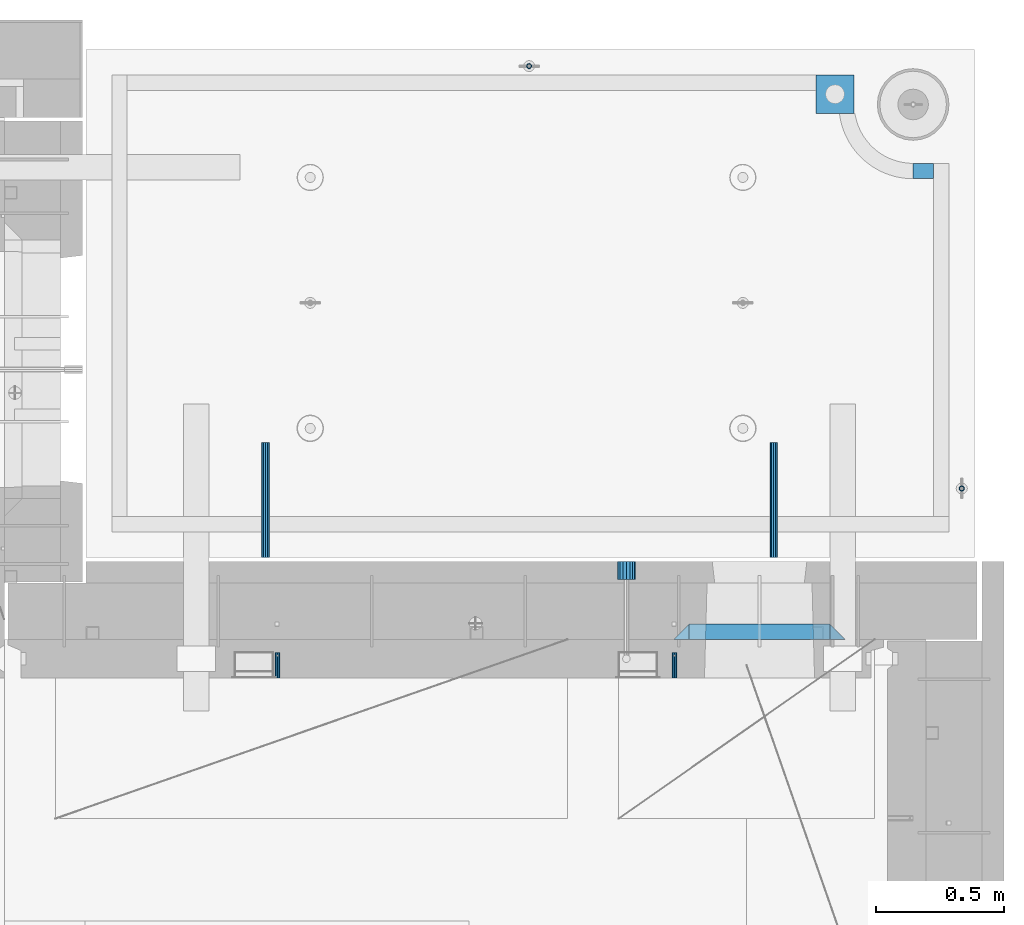
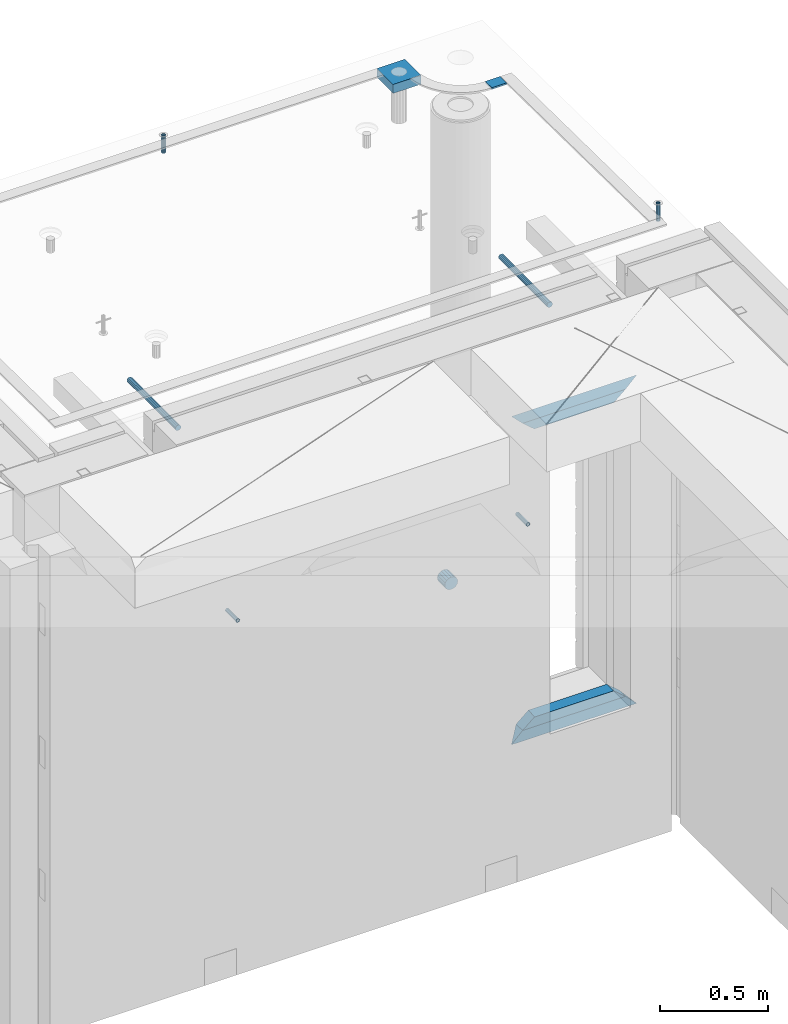
# One storey, part 165 of 341: 13 beams, 8 elements without a shape of their own.
"""IFC2X3 building model written with IfcOpenShell, lengths in millimetres."""

from ifc_helpers import new_model, si_unit, frame, origin_with_axes, place, context, subcontext, project, spatial, faceted_brep, material, type_object, element, aggregate, save


model = new_model("IFC2X3")

# Units and contexts
model_context = context("Model", 3, precision=1e-05, world=origin_with_axes())
body_context = subcontext(model_context, "Body", "Model", "MODEL_VIEW")
ifc_project = project(units=[si_unit("LENGTHUNIT", "METRE", prefix="MILLI"), si_unit("AREAUNIT", "SQUARE_METRE"), si_unit("VOLUMEUNIT", "CUBIC_METRE"), si_unit("MASSUNIT", "GRAM", prefix="KILO"), si_unit("TIMEUNIT", "SECOND"), si_unit("PLANEANGLEUNIT", "RADIAN"), si_unit("SOLIDANGLEUNIT", "STERADIAN"), si_unit("THERMODYNAMICTEMPERATUREUNIT", "DEGREE_CELSIUS"), si_unit("LUMINOUSINTENSITYUNIT", "LUMEN")], contexts=[model_context])

# Site, building, storey
site_placement = place(None, origin_with_axes())
site = spatial("IfcSite", under=ifc_project, at=site_placement, CompositionType="ELEMENT")
building_placement = place(site_placement, origin_with_axes())
building = spatial("IfcBuilding", under=site, at=building_placement, CompositionType="ELEMENT")
storey_placement = place(building_placement, origin_with_axes())
storey = spatial("IfcBuildingStorey", under=building, at=storey_placement, Name="5", CompositionType="ELEMENT", Elevation=0.0)

# Assembly, beam
assembly_1_placement = place(storey_placement, origin_with_axes())
assembly_1 = element("IfcElementAssembly", 1, at=assembly_1_placement, inside=storey, AssemblyPlace="NOTDEFINED", PredefinedType="REINFORCEMENT_UNIT")
ifc_material_1 = material(Name="CONCRETE/Concrete_Undefined")
beam_type_1 = type_object("IfcBeamType", PredefinedType="NOTDEFINED")
beam_1_placement = place(assembly_1_placement, frame((34629.9388785763, 22710.0581582943, 96683.7829850799), z_axis=(-0.00137996799978526, 4.79999998713041e-07, 0.999999047843591), x_axis=(0.999998987436327, -0.000347584000148161, 0.00137996800063524)))
beam_1 = element("IfcBeam", 2, at=beam_1_placement, type_object=beam_type_1, material=ifc_material_1, context=body_context, shape_type="Brep", body=[
    faceted_brep([(0.0, 75.0, -25.0), (1.81898940354586e-12, 75.0, 25.0), (149.995899162379, 75.0, 25.0), (149.995899158246, 75.0000000000036, -25.0), (1.81898940354586e-12, -75.0000000000009, 25.0), (149.995899162386, -75.0, 25.0), (0.0, -75.0, -25.0), (149.995899158239, -74.9999999999964, -25.0)], [[[0, 1, 2, 3]], [[1, 4, 5, 2]], [[4, 6, 7, 5]], [[6, 0, 3, 7]], [[5, 7, 3, 2]], [[6, 4, 1, 0]]]),
])

# Assemblies, beams
assembly_2_placement = place(storey_placement, origin_with_axes())
assembly_2 = element("IfcElementAssembly", 3, at=assembly_2_placement, inside=storey, AssemblyPlace="NOTDEFINED", PredefinedType="REINFORCEMENT_UNIT")
assembly_3_placement = place(assembly_2_placement, origin_with_axes())
assembly_3 = element("IfcElementAssembly", 4, at=assembly_3_placement, Name="Steel Assembly", AssemblyPlace="NOTDEFINED", PredefinedType="RIGID_FRAME")
ifc_material_2 = material(Name="STEEL/Steel_Undefined")
beam_type_2 = type_object("IfcBeamType", PredefinedType="NOTDEFINED")
beam_2_placement = place(assembly_3_placement, frame((34077.8782931989, 20429.9951872276, 95755.0), z_axis=(-1.0, 3.00000001838171e-08, 0.0), x_axis=(0.0, 1.0, 0.0)))
beam_2 = element("IfcBeam", 5, at=beam_2_placement, type_object=beam_type_2, material=ifc_material_2, Name="M16", context=body_context, shape_type="Brep", body=[
    faceted_brep([(0.0, -8.49999999999272, -1.45519152283669e-11), (0.0, -7.36121593215648, 4.24999999998545), (100.000000000262, -7.36121593215648, 4.24999999998545), (100.000000000262, -8.49999999999272, -1.45519152283669e-11), (0.0, -4.24999999998545, 7.36121593216376), (100.000000000262, -4.24999999998545, 7.36121593216376), (0.0, 1.45519152283669e-11, 8.49999999998545), (100.000000000262, 1.45519152283669e-11, 8.49999999998545), (0.0, 4.25000000001455, 7.36121593216376), (100.000000000262, 4.25000000001455, 7.36121593216376), (0.0, 7.36121593217104, 4.24999999998545), (100.000000000262, 7.36121593217104, 4.24999999998545), (0.0, 8.50000000000728, 0.0), (100.000000000262, 8.50000000000728, 0.0), (0.0, 7.36121593217104, -4.25000000001455), (100.000000000262, 7.36121593217104, -4.25000000001455), (0.0, 4.25000000000728, -7.36121593219286), (100.000000000262, 4.25000000000728, -7.36121593219286), (0.0, 7.27595761418343e-12, -8.5), (100.000000000262, 7.27595761418343e-12, -8.5), (0.0, -4.24999999999272, -7.36121593217831), (100.000000000262, -4.24999999999272, -7.36121593217831), (0.0, -7.36121593215648, -4.25), (100.000000000262, -7.36121593215648, -4.25), (0.0, -10.4999999999927, -1.45519152283669e-11), (0.0, -9.09326673972828, -5.25000000001455), (100.000000000262, -9.09326673972828, -5.25000000001455), (100.000000000262, -10.4999999999927, -1.45519152283669e-11), (0.0, -5.24999999998545, -9.09326673974283), (100.000000000262, -5.24999999998545, -9.09326673974283), (0.0, 7.27595761418343e-12, -10.5), (100.000000000262, 7.27595761418343e-12, -10.5), (0.0, 5.25000000001455, -9.09326673975738), (100.000000000262, 5.25000000001455, -9.09326673975738), (0.0, 9.09326673975011, -5.25000000001455), (100.000000000262, 9.09326673975011, -5.25000000001455), (0.0, 10.5000000000073, -1.45519152283669e-11), (100.000000000262, 10.5000000000073, -1.45519152283669e-11), (0.0, 9.09326673975011, 5.25), (100.000000000262, 9.09326673975011, 5.25), (0.0, 5.25000000000728, 9.09326673972828), (100.000000000262, 5.25000000000728, 9.09326673972828), (0.0, 1.45519152283669e-11, 10.4999999999854), (100.000000000262, 1.45519152283669e-11, 10.4999999999854), (0.0, -5.24999999999272, 9.09326673972828), (100.000000000262, -5.24999999999272, 9.09326673972828), (0.0, -9.09326673972828, 5.24999999998545), (100.000000000262, -9.09326673972828, 5.24999999998545)], [[[0, 1, 2, 3]], [[1, 4, 5, 2]], [[4, 6, 7, 5]], [[6, 8, 9, 7]], [[8, 10, 11, 9]], [[10, 12, 13, 11]], [[12, 14, 15, 13]], [[14, 16, 17, 15]], [[16, 18, 19, 17]], [[18, 20, 21, 19]], [[20, 22, 23, 21]], [[22, 0, 3, 23]], [[24, 25, 26, 27]], [[25, 28, 29, 26]], [[28, 30, 31, 29]], [[30, 32, 33, 31]], [[32, 34, 35, 33]], [[34, 36, 37, 35]], [[36, 38, 39, 37]], [[38, 40, 41, 39]], [[40, 42, 43, 41]], [[42, 44, 45, 43]], [[44, 46, 47, 45]], [[46, 24, 27, 47]], [[29, 31, 33, 35, 37, 39, 41, 43, 45, 47, 27, 26], [5, 7, 9, 11, 13, 15, 17, 19, 21, 23, 3, 2]], [[46, 44, 42, 40, 38, 36, 34, 32, 30, 28, 25, 24], [22, 20, 18, 16, 14, 12, 10, 8, 6, 4, 1, 0]]]),
])
aggregate(assembly_3, [beam_2])
assembly_4_placement = place(assembly_2_placement, origin_with_axes())
assembly_4 = element("IfcElementAssembly", 6, at=assembly_4_placement, Name="Steel Assembly", AssemblyPlace="NOTDEFINED", PredefinedType="RIGID_FRAME")
beam_3_placement = place(assembly_4_placement, frame((32527.3782931989, 20429.9951872276, 95755.0), z_axis=(-1.0, 3.00000001838171e-08, 0.0), x_axis=(0.0, 1.0, 0.0)))
beam_3 = element("IfcBeam", 7, at=beam_3_placement, type_object=beam_type_2, material=ifc_material_2, Name="M16", context=body_context, shape_type="Brep", body=[
    faceted_brep([(0.0, -8.49999999999272, -1.45519152283669e-11), (0.0, -7.36121593215648, 4.24999999998545), (100.000000000262, -7.36121593215648, 4.24999999998545), (100.000000000262, -8.49999999999272, -1.45519152283669e-11), (0.0, -4.24999999998545, 7.36121593216376), (100.000000000262, -4.24999999998545, 7.36121593216376), (0.0, 1.45519152283669e-11, 8.49999999998545), (100.000000000262, 1.45519152283669e-11, 8.49999999998545), (0.0, 4.25000000001455, 7.36121593216376), (100.000000000262, 4.25000000001455, 7.36121593216376), (0.0, 7.36121593217104, 4.24999999998545), (100.000000000262, 7.36121593217104, 4.24999999998545), (0.0, 8.50000000000728, 0.0), (100.000000000262, 8.50000000000728, 0.0), (0.0, 7.36121593217104, -4.25000000001455), (100.000000000262, 7.36121593217104, -4.25000000001455), (0.0, 4.25000000000728, -7.36121593219286), (100.000000000262, 4.25000000000728, -7.36121593219286), (0.0, 7.27595761418343e-12, -8.5), (100.000000000262, 7.27595761418343e-12, -8.5), (0.0, -4.24999999999272, -7.36121593217831), (100.000000000262, -4.24999999999272, -7.36121593217831), (0.0, -7.36121593215648, -4.25), (100.000000000262, -7.36121593215648, -4.25), (0.0, -10.4999999999927, -1.45519152283669e-11), (0.0, -9.09326673972828, -5.25000000001455), (100.000000000262, -9.09326673972828, -5.25000000001455), (100.000000000262, -10.4999999999927, -1.45519152283669e-11), (0.0, -5.24999999998545, -9.09326673974283), (100.000000000262, -5.24999999998545, -9.09326673974283), (0.0, 7.27595761418343e-12, -10.5), (100.000000000262, 7.27595761418343e-12, -10.5), (0.0, 5.25000000001455, -9.09326673975738), (100.000000000262, 5.25000000001455, -9.09326673975738), (0.0, 9.09326673975011, -5.25000000001455), (100.000000000262, 9.09326673975011, -5.25000000001455), (0.0, 10.5000000000073, -1.45519152283669e-11), (100.000000000262, 10.5000000000073, -1.45519152283669e-11), (0.0, 9.09326673975011, 5.25), (100.000000000262, 9.09326673975011, 5.25), (0.0, 5.25000000000728, 9.09326673972828), (100.000000000262, 5.25000000000728, 9.09326673972828), (0.0, 1.45519152283669e-11, 10.4999999999854), (100.000000000262, 1.45519152283669e-11, 10.4999999999854), (0.0, -5.24999999999272, 9.09326673972828), (100.000000000262, -5.24999999999272, 9.09326673972828), (0.0, -9.09326673972828, 5.24999999998545), (100.000000000262, -9.09326673972828, 5.24999999998545)], [[[0, 1, 2, 3]], [[1, 4, 5, 2]], [[4, 6, 7, 5]], [[6, 8, 9, 7]], [[8, 10, 11, 9]], [[10, 12, 13, 11]], [[12, 14, 15, 13]], [[14, 16, 17, 15]], [[16, 18, 19, 17]], [[18, 20, 21, 19]], [[20, 22, 23, 21]], [[22, 0, 3, 23]], [[24, 25, 26, 27]], [[25, 28, 29, 26]], [[28, 30, 31, 29]], [[30, 32, 33, 31]], [[32, 34, 35, 33]], [[34, 36, 37, 35]], [[36, 38, 39, 37]], [[38, 40, 41, 39]], [[40, 42, 43, 41]], [[42, 44, 45, 43]], [[44, 46, 47, 45]], [[46, 24, 27, 47]], [[29, 31, 33, 35, 37, 39, 41, 43, 45, 47, 27, 26], [5, 7, 9, 11, 13, 15, 17, 19, 21, 23, 3, 2]], [[46, 44, 42, 40, 38, 36, 34, 32, 30, 28, 25, 24], [22, 20, 18, 16, 14, 12, 10, 8, 6, 4, 1, 0]]]),
])
aggregate(assembly_4, [beam_3])

# Assembly, beam
assembly_5_placement = place(assembly_1_placement, origin_with_axes())
assembly_5 = element("IfcElementAssembly", 8, at=assembly_5_placement, Name="Steel Assembly", AssemblyPlace="NOTDEFINED", PredefinedType="RIGID_FRAME")
ifc_material_3 = material(Name="STEEL/1.4301")
beam_type_3 = type_object("IfcBeamType", PredefinedType="NOTDEFINED")
beam_4_placement = place(assembly_5_placement, frame((35199.9998195516, 21170.0002421324, 96731.000000009), z_axis=(0.999999999984675, 3.40399999908427e-06, -4.36599999368485e-06), x_axis=(-4.36599999292741e-06, 0.0, -0.999999999990469)))
beam_4 = element("IfcBeam", 9, at=beam_4_placement, type_object=beam_type_3, material=ifc_material_3, context=body_context, shape_type="Brep", body=[
    faceted_brep([(0.0, -8.0, 0.0), (0.0, -6.92820323027263, 4.0), (100.000000000029, -6.92820323027263, 4.0), (100.000000000029, -7.99999999999636, 0.0), (0.0, -4.0, 6.92820323027627), (100.000000000029, -4.0, 6.92820323027536), (0.0, 0.0, 8.0), (100.000000000029, 3.63797880709171e-12, 8.0), (0.0, 4.0, 6.92820323027627), (100.000000000029, 4.0, 6.92820323027536), (0.0, 6.92820323027263, 4.0), (100.000000000029, 6.92820323027627, 3.99999999999909), (0.0, 8.0, 0.0), (100.000000000029, 8.0, 0.0), (0.0, 6.92820323027263, -4.0), (100.000000000029, 6.92820323027627, -4.00000000000091), (0.0, 4.0, -6.92820323027627), (100.000000000029, 4.00000000000364, -6.92820323027536), (0.0, 0.0, -8.0), (100.000000000029, 3.63797880709171e-12, -8.00000000000091), (0.0, -4.0, -6.92820323027627), (100.000000000029, -3.99999999999636, -6.92820323027627), (0.0, -6.92820323027263, -4.0), (100.000000000029, -6.92820323027263, -4.0), (0.0, -10.4999999999927, -1.45519152283669e-11), (0.0, -9.09326673972828, -5.25000000001455), (100.000000000262, -9.09326673972828, -5.25000000001455), (100.000000000262, -10.4999999999927, -1.45519152283669e-11), (0.0, -5.24999999998545, -9.09326673974283), (100.000000000262, -5.24999999998545, -9.09326673974283), (0.0, 7.27595761418343e-12, -10.5), (100.000000000262, 7.27595761418343e-12, -10.5), (0.0, 5.25000000001455, -9.09326673975738), (100.000000000262, 5.25000000001455, -9.09326673975738), (0.0, 9.09326673975011, -5.25000000001455), (100.000000000262, 9.09326673975011, -5.25000000001455), (0.0, 10.5000000000073, -1.45519152283669e-11), (100.000000000262, 10.5000000000073, -1.45519152283669e-11), (0.0, 9.09326673975011, 5.25), (100.000000000262, 9.09326673975011, 5.25), (0.0, 5.25000000000728, 9.09326673972828), (100.000000000262, 5.25000000000728, 9.09326673972828), (0.0, 1.45519152283669e-11, 10.4999999999854), (100.000000000262, 1.45519152283669e-11, 10.4999999999854), (0.0, -5.24999999999272, 9.09326673972828), (100.000000000262, -5.24999999999272, 9.09326673972828), (0.0, -9.09326673972828, 5.24999999998545), (100.000000000262, -9.09326673972828, 5.24999999998545)], [[[0, 1, 2, 3]], [[1, 4, 5, 2]], [[4, 6, 7, 5]], [[6, 8, 9, 7]], [[8, 10, 11, 9]], [[10, 12, 13, 11]], [[12, 14, 15, 13]], [[14, 16, 17, 15]], [[16, 18, 19, 17]], [[18, 20, 21, 19]], [[20, 22, 23, 21]], [[22, 0, 3, 23]], [[24, 25, 26, 27]], [[25, 28, 29, 26]], [[28, 30, 31, 29]], [[30, 32, 33, 31]], [[32, 34, 35, 33]], [[34, 36, 37, 35]], [[36, 38, 39, 37]], [[38, 40, 41, 39]], [[40, 42, 43, 41]], [[42, 44, 45, 43]], [[44, 46, 47, 45]], [[46, 24, 27, 47]], [[29, 31, 33, 35, 37, 39, 41, 43, 45, 47, 27, 26], [5, 7, 9, 11, 13, 15, 17, 19, 21, 23, 3, 2]], [[46, 44, 42, 40, 38, 36, 34, 32, 30, 28, 25, 24], [22, 20, 18, 16, 14, 12, 10, 8, 6, 4, 1, 0]]]),
])
aggregate(assembly_5, [beam_4])

assembly_6_placement = place(assembly_1_placement, origin_with_axes())
assembly_6 = element("IfcElementAssembly", 10, at=assembly_6_placement, Name="Steel Assembly", AssemblyPlace="NOTDEFINED", PredefinedType="RIGID_FRAME")
beam_5_placement = place(assembly_6_placement, frame((33509.996713687, 22819.9969702071, 96706.0000000179), z_axis=(3.62999999922404e-06, -0.999999999993412, 0.0), x_axis=(-4.36599999292741e-06, 0.0, -0.999999999990469)))
beam_5 = element("IfcBeam", 11, at=beam_5_placement, type_object=beam_type_3, material=ifc_material_3, context=body_context, shape_type="Brep", body=[
    faceted_brep([(0.0, -8.0, 0.0), (0.0, -6.92820323027263, 4.0), (100.000000000029, -6.92820323027263, 4.0), (100.000000000029, -7.99999999999636, 0.0), (0.0, -4.0, 6.92820323027627), (100.000000000029, -4.0, 6.92820323027536), (0.0, 0.0, 8.0), (100.000000000029, 3.63797880709171e-12, 8.0), (0.0, 4.0, 6.92820323027627), (100.000000000029, 4.0, 6.92820323027536), (0.0, 6.92820323027263, 4.0), (100.000000000029, 6.92820323027627, 3.99999999999909), (0.0, 8.0, 0.0), (100.000000000029, 8.0, 0.0), (0.0, 6.92820323027263, -4.0), (100.000000000029, 6.92820323027627, -4.00000000000091), (0.0, 4.0, -6.92820323027627), (100.000000000029, 4.00000000000364, -6.92820323027536), (0.0, 0.0, -8.0), (100.000000000029, 3.63797880709171e-12, -8.00000000000091), (0.0, -4.0, -6.92820323027627), (100.000000000029, -3.99999999999636, -6.92820323027627), (0.0, -6.92820323027263, -4.0), (100.000000000029, -6.92820323027263, -4.0), (0.0, -10.4999999999927, -1.45519152283669e-11), (0.0, -9.09326673972828, -5.25000000001455), (100.000000000262, -9.09326673972828, -5.25000000001455), (100.000000000262, -10.4999999999927, -1.45519152283669e-11), (0.0, -5.24999999998545, -9.09326673974283), (100.000000000262, -5.24999999998545, -9.09326673974283), (0.0, 7.27595761418343e-12, -10.5), (100.000000000262, 7.27595761418343e-12, -10.5), (0.0, 5.25000000001455, -9.09326673975738), (100.000000000262, 5.25000000001455, -9.09326673975738), (0.0, 9.09326673975011, -5.25000000001455), (100.000000000262, 9.09326673975011, -5.25000000001455), (0.0, 10.5000000000073, -1.45519152283669e-11), (100.000000000262, 10.5000000000073, -1.45519152283669e-11), (0.0, 9.09326673975011, 5.25), (100.000000000262, 9.09326673975011, 5.25), (0.0, 5.25000000000728, 9.09326673972828), (100.000000000262, 5.25000000000728, 9.09326673972828), (0.0, 1.45519152283669e-11, 10.4999999999854), (100.000000000262, 1.45519152283669e-11, 10.4999999999854), (0.0, -5.24999999999272, 9.09326673972828), (100.000000000262, -5.24999999999272, 9.09326673972828), (0.0, -9.09326673972828, 5.24999999998545), (100.000000000262, -9.09326673972828, 5.24999999998545)], [[[0, 1, 2, 3]], [[1, 4, 5, 2]], [[4, 6, 7, 5]], [[6, 8, 9, 7]], [[8, 10, 11, 9]], [[10, 12, 13, 11]], [[12, 14, 15, 13]], [[14, 16, 17, 15]], [[16, 18, 19, 17]], [[18, 20, 21, 19]], [[20, 22, 23, 21]], [[22, 0, 3, 23]], [[24, 25, 26, 27]], [[25, 28, 29, 26]], [[28, 30, 31, 29]], [[30, 32, 33, 31]], [[32, 34, 35, 33]], [[34, 36, 37, 35]], [[36, 38, 39, 37]], [[38, 40, 41, 39]], [[40, 42, 43, 41]], [[42, 44, 45, 43]], [[44, 46, 47, 45]], [[46, 24, 27, 47]], [[29, 31, 33, 35, 37, 39, 41, 43, 45, 47, 27, 26], [5, 7, 9, 11, 13, 15, 17, 19, 21, 23, 3, 2]], [[46, 44, 42, 40, 38, 36, 34, 32, 30, 28, 25, 24], [22, 20, 18, 16, 14, 12, 10, 8, 6, 4, 1, 0]]]),
])
aggregate(assembly_6, [beam_5])

# Beam
ifc_material_4 = material()
beam_type_4 = type_object("IfcBeamType", Name="D70", PredefinedType="NOTDEFINED")
beam_6_placement = place(assembly_2_placement, frame((33889.9951872276, 20884.9951872276, 95255.0), z_axis=(0.0, 0.0, 1.0), x_axis=(0.0, -1.0, 0.0)))
beam_6 = element("IfcBeam", 12, at=beam_6_placement, type_object=beam_type_4, material=ifc_material_4, ObjectType="D70", context=body_context, shape_type="Brep", body=[
    faceted_brep([(0.0, -35.0, 0.0), (0.0, -32.3357836378964, -13.3939201327739), (70.0, -32.3357836378964, -13.3939201327739), (70.0, -35.0, 0.0), (0.0, -24.7487373415279, -24.7487373415352), (70.0, -24.7487373415279, -24.7487373415352), (0.0, -13.3939201327776, -32.3357836379), (70.0, -13.3939201327776, -32.3357836379), (0.0, 0.0, -35.0), (70.0, 0.0, -35.0), (0.0, 13.3939201327776, -32.3357836379), (70.0, 13.3939201327776, -32.3357836379), (0.0, 24.7487373415279, -24.7487373415352), (70.0, 24.7487373415279, -24.7487373415352), (0.0, 32.3357836378964, -13.3939201327739), (70.0, 32.3357836378964, -13.3939201327739), (0.0, 35.0, 0.0), (70.0, 35.0, 0.0), (0.0, 32.3357836378964, 13.3939201327739), (70.0, 32.3357836378964, 13.3939201327739), (0.0, 24.7487373415279, 24.7487373415352), (70.0, 24.7487373415279, 24.7487373415352), (0.0, 13.3939201327776, 32.3357836379), (70.0, 13.3939201327776, 32.3357836379), (0.0, 0.0, 35.0), (70.0, 0.0, 35.0), (0.0, -13.3939201327776, 32.3357836379), (70.0, -13.3939201327776, 32.3357836379), (0.0, -24.7487373415279, 24.7487373415352), (70.0, -24.7487373415279, 24.7487373415352), (0.0, -32.3357836378964, 13.3939201327739), (70.0, -32.3357836378964, 13.3939201327739)], [[[0, 1, 2, 3]], [[1, 4, 5, 2]], [[4, 6, 7, 5]], [[6, 8, 9, 7]], [[8, 10, 11, 9]], [[10, 12, 13, 11]], [[12, 14, 15, 13]], [[14, 16, 17, 15]], [[16, 18, 19, 17]], [[18, 20, 21, 19]], [[20, 22, 23, 21]], [[22, 24, 25, 23]], [[24, 26, 27, 25]], [[26, 28, 29, 27]], [[28, 30, 31, 29]], [[30, 0, 3, 31]], [[5, 7, 9, 11, 13, 15, 17, 19, 21, 23, 25, 27, 29, 31, 3, 2]], [[30, 28, 26, 24, 22, 20, 18, 16, 14, 12, 10, 8, 6, 4, 1, 0]]]),
])

# Assembly, beam
assembly_7_placement = place(assembly_1_placement, origin_with_axes())
assembly_7 = element("IfcElementAssembly", 13, at=assembly_7_placement, Name="Steel Assembly", AssemblyPlace="NOTDEFINED", PredefinedType="RIGID_FRAME")
ifc_material_5 = material(Name="STEEL/S235JR")
beam_type_5 = type_object("IfcBeamType", Name="D30", PredefinedType="NOTDEFINED")
beam_7_placement = place(assembly_7_placement, frame((32479.9998567563, 20900.0253394533, 96575.0), z_axis=(0.0, 0.0, 1.0), x_axis=(0.0, 1.0, 0.0)))
beam_7 = element("IfcBeam", 14, at=beam_7_placement, type_object=beam_type_5, material=ifc_material_5, Name="Rd30", ObjectType="D30", context=body_context, shape_type="Brep", body=[
    faceted_brep([(0.0, -15.0, 0.0), (0.0, -12.9903810567666, -7.5), (450.0, -12.9903810567666, -7.5), (450.0, -15.0, 0.0), (0.0, -7.5, -12.9903810567666), (450.0, -7.5, -12.990381056763), (0.0, 0.0, -15.0), (450.0, 0.0, -15.0), (0.0, 7.5, -12.9903810567666), (450.0, 7.5, -12.990381056763), (0.0, 12.9903810567666, -7.5), (450.0, 12.9903810567666, -7.5), (0.0, 15.0, 0.0), (450.0, 15.0, 0.0), (0.0, 12.9903810567666, 7.5), (450.0, 12.9903810567666, 7.5), (0.0, 7.5, 12.9903810567666), (450.0, 7.5, 12.990381056763), (0.0, 0.0, 15.0), (450.0, 0.0, 15.0), (0.0, -7.5, 12.9903810567666), (450.0, -7.5, 12.990381056763), (0.0, -12.9903810567666, 7.5), (450.0, -12.9903810567666, 7.5)], [[[0, 1, 2, 3]], [[1, 4, 5, 2]], [[4, 6, 7, 5]], [[6, 8, 9, 7]], [[8, 10, 11, 9]], [[10, 12, 13, 11]], [[12, 14, 15, 13]], [[14, 16, 17, 15]], [[16, 18, 19, 17]], [[18, 20, 21, 19]], [[20, 22, 23, 21]], [[22, 0, 3, 23]], [[5, 7, 9, 11, 13, 15, 17, 19, 21, 23, 3, 2]], [[22, 20, 18, 16, 14, 12, 10, 8, 6, 4, 1, 0]]]),
])
aggregate(assembly_7, [beam_7])

assembly_8_placement = place(assembly_1_placement, origin_with_axes())
assembly_8 = element("IfcElementAssembly", 15, at=assembly_8_placement, Name="Steel Assembly", AssemblyPlace="NOTDEFINED", PredefinedType="RIGID_FRAME")
beam_8_placement = place(assembly_8_placement, frame((34464.9998570066, 20900.0152136098, 96575.0), z_axis=(0.0, 0.0, 1.0), x_axis=(0.0, 1.0, 0.0)))
beam_8 = element("IfcBeam", 16, at=beam_8_placement, type_object=beam_type_5, material=ifc_material_5, Name="Rd30", ObjectType="D30", context=body_context, shape_type="Brep", body=[
    faceted_brep([(0.0, -15.0, 0.0), (0.0, -12.9903810567666, -7.5), (450.0, -12.9903810567666, -7.5), (450.0, -15.0, 0.0), (0.0, -7.5, -12.9903810567666), (450.0, -7.5, -12.990381056763), (0.0, 0.0, -15.0), (450.0, 0.0, -15.0), (0.0, 7.5, -12.9903810567666), (450.0, 7.5, -12.990381056763), (0.0, 12.9903810567666, -7.5), (450.0, 12.9903810567666, -7.5), (0.0, 15.0, 0.0), (450.0, 15.0, 0.0), (0.0, 12.9903810567666, 7.5), (450.0, 12.9903810567666, 7.5), (0.0, 7.5, 12.9903810567666), (450.0, 7.5, 12.990381056763), (0.0, 0.0, 15.0), (450.0, 0.0, 15.0), (0.0, -7.5, 12.9903810567666), (450.0, -7.5, 12.990381056763), (0.0, -12.9903810567666, 7.5), (450.0, -12.9903810567666, 7.5)], [[[0, 1, 2, 3]], [[1, 4, 5, 2]], [[4, 6, 7, 5]], [[6, 8, 9, 7]], [[8, 10, 11, 9]], [[10, 12, 13, 11]], [[12, 14, 15, 13]], [[14, 16, 17, 15]], [[16, 18, 19, 17]], [[18, 20, 21, 19]], [[20, 22, 23, 21]], [[22, 0, 3, 23]], [[5, 7, 9, 11, 13, 15, 17, 19, 21, 23, 3, 2]], [[22, 20, 18, 16, 14, 12, 10, 8, 6, 4, 1, 0]]]),
])
aggregate(assembly_8, [beam_8])

# Beam
beam_type_6 = type_object("IfcBeamType", PredefinedType="NOTDEFINED")
beam_9_placement = place(assembly_1_placement, frame((35010.002279683, 22410.0178789446, 96707.3588950719), z_axis=(-0.00268578700072087, 6.80000012107549e-08, 0.999996393267587), x_axis=(0.999996392945569, -2.53780000005236e-05, 0.00268578699982978)))
beam_9 = element("IfcBeam", 17, at=beam_9_placement, type_object=beam_type_6, material=ifc_material_1, context=body_context, shape_type="Brep", body=[
    faceted_brep([(2.5465851649642e-11, 29.9999999999982, -4.99999999998545), (-2.91038304567337e-11, 29.9999999999982, 5.0), (80.0148896796745, 29.9999999999964, 4.99999999998545), (80.0148896796454, 29.9999999999964, -5.00000000001455), (-2.5465851649642e-11, -30.0000000000018, 5.0), (80.0148896796745, -30.0000000000036, 4.99999999998545), (2.72848410531878e-11, -30.0000000000018, -4.99999999998545), (80.0148896796527, -30.0000000000036, -5.0)], [[[0, 1, 2, 3]], [[1, 4, 5, 2]], [[4, 6, 7, 5]], [[6, 0, 3, 7]], [[5, 7, 3, 2]], [[6, 4, 1, 0]]]),
])

aggregate(assembly_1, [assembly_5, assembly_6, assembly_7, assembly_8, beam_9, beam_1])

ifc_material_6 = material(Name="CONCRETE/C25/30")
beam_type_7 = type_object("IfcBeamType", PredefinedType="NOTDEFINED")
beam_10_placement = place(assembly_2_placement, frame((34684.9994055559, 20609.9951872276, 96185.0), z_axis=(0.0, 0.0, -1.0), x_axis=(-1.0, 3.00000001838171e-08, 0.0)))
beam_10 = element("IfcBeam", 18, at=beam_10_placement, type_object=beam_type_7, material=ifc_material_6, Name="SK", context=body_context, shape_type="Brep", body=[
    faceted_brep([(64.057950538423, -30.0, 24.9068147351645), (65.6795721600429, 30.0, 26.2967761248292), (0.0, 30.0, -30.0), (0.0, -30.0, -30.0), (64.057950538423, -30.0, 24.0540540540533), (65.6795721600429, 30.0, 25.6756756756804), (485.939842430322, -30.0, 24.0540540540533), (484.318220808702, 30.0, 25.6756756756804), (484.318220808702, 30.0, 26.293436281092), (549.993896484375, 30.0, -30.0), (549.993896484375, -30.0, -30.0), (485.939842430322, -30.0, 24.9034748914273)], [[[0, 1, 2, 3]], [[4, 5, 1, 0]], [[6, 7, 5, 4]], [[2, 1, 5, 7, 8, 9]], [[3, 2, 9, 10]], [[6, 4, 0, 3, 10, 11]], [[7, 6, 11, 8]], [[10, 9, 8, 11]]]),
])

beam_11_placement = place(assembly_2_placement, frame((34744.9994055559, 20609.9951872276, 96245.0), z_axis=(0.0, 0.0, -1.0), x_axis=(-1.0, 3.00000001838171e-08, 0.0)))
beam_11 = element("IfcBeam", 19, at=beam_11_placement, type_object=beam_type_7, material=ifc_material_6, Name="SK", context=body_context, shape_type="Brep", body=[
    faceted_brep([(60.0000000000073, 30.0, 30.0), (0.0, -30.0, -30.0), (60.0000000000073, -30.0, 30.0), (609.993896484397, 30.0, 30.0), (669.993896484375, -30.0, -30.0), (609.993896484397, -30.0, 30.0)], [[[0, 1, 2]], [[1, 0, 3, 4]], [[2, 1, 4, 5]], [[0, 2, 5, 3]], [[4, 3, 5]]]),
])

beam_12_placement = place(assembly_2_placement, frame((34075.0055090716, 20609.9951872276, 94450.0), z_axis=(0.0, 0.0, 1.0), x_axis=(1.0, 0.0, 0.0)))
beam_12 = element("IfcBeam", 20, at=beam_12_placement, type_object=beam_type_7, material=ifc_material_6, Name="SK", context=body_context, shape_type="Brep", body=[
    faceted_brep([(669.993896484375, -30.0, -30.0), (609.993896484397, 30.0, 30.0), (609.993896484397, -30.0, 30.0), (60.0000000000073, 30.0, 30.0), (60.0000000000073, -30.0, 30.0), (0.0, -30.0, -30.0)], [[[0, 1, 2]], [[3, 4, 2, 1]], [[4, 5, 0, 2]], [[5, 3, 1, 0]], [[3, 5, 4]]]),
])

beam_13_placement = place(assembly_2_placement, frame((34135.0055090716, 20609.9951872276, 94510.0), z_axis=(0.0, 0.0, 1.0), x_axis=(1.0, 0.0, 0.0)))
beam_13 = element("IfcBeam", 21, at=beam_13_placement, type_object=beam_type_7, material=ifc_material_6, Name="SK", context=body_context, shape_type="Brep", body=[
    faceted_brep([(485.935945945952, -30.0, 24.9068147351645), (549.993896484375, -30.0, -30.0), (549.993896484375, 30.0, -30.0), (484.314324324332, 30.0, 26.2967761248292), (484.314324324332, 30.0, 25.6756756756804), (485.935945945952, -30.0, 24.0540540540533), (65.6756756756768, 30.0, 25.6756756756804), (64.0540540540533, -30.0, 24.0540540540533), (65.6756756756768, 30.0, 26.293436281092), (64.0540540540533, -30.0, 24.9034748914419), (0.0, -30.0, -30.0), (0.0, 30.0, -30.0)], [[[0, 1, 2, 3]], [[4, 5, 0, 3]], [[5, 4, 6, 7]], [[7, 6, 8, 9]], [[1, 0, 5, 7, 9, 10]], [[10, 11, 2, 1]], [[6, 4, 3, 2, 11, 8]], [[10, 9, 8, 11]]]),
])

aggregate(assembly_2, [beam_6, assembly_3, assembly_4, beam_10, beam_11, beam_12, beam_13])

save(model, "model.ifc")
